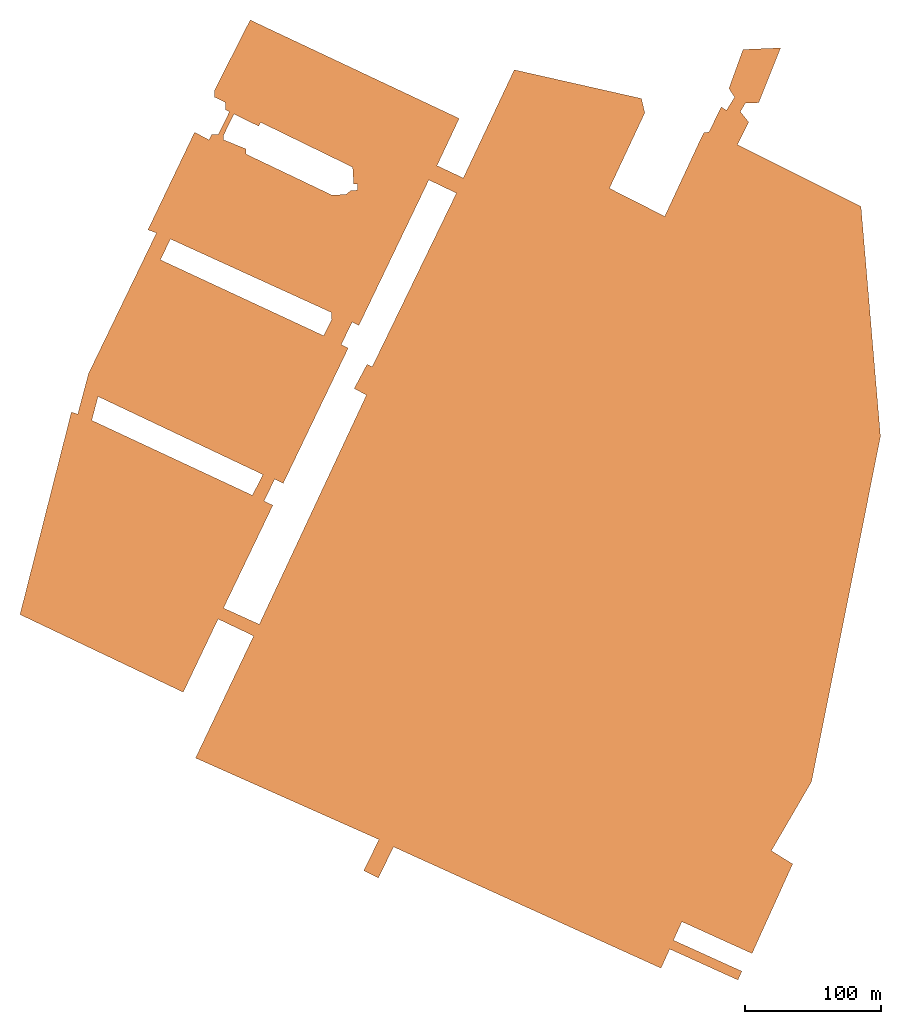
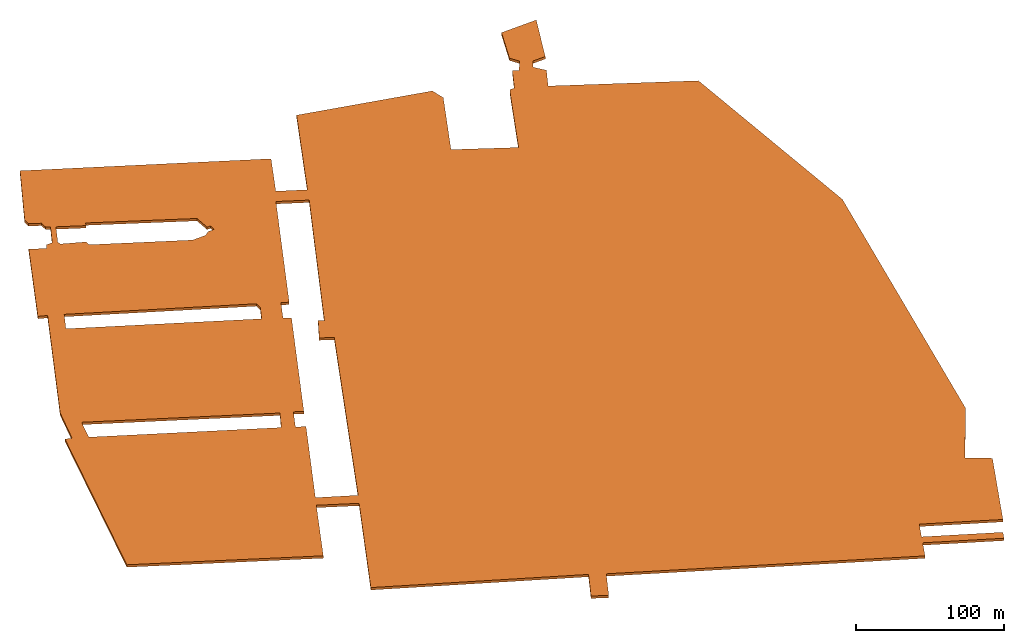
# One storey: 1 proxy.
"""IFC2X3 building model written with IfcOpenShell, lengths in millimetres."""

from ifc_helpers import new_model, entity, si_unit, converted_unit, direction, frame, origin, place, context, subcontext, project, spatial, polyline, outline, extrude, source, transform, mapped, material, element, save


model = new_model("IFC2X3")

# Units and contexts
model_context = context("Model", 3, precision=1e-06, world=origin(), true_north=direction((2.0, -0.438371146789077, 0.898794046299167)))
context_of_model = context(None, 3, precision=1e-06, world=origin(), true_north=direction((2.0, -0.438371146789077, 0.898794046299167)))
body_context = subcontext(model_context, "Body", "Model", "MODEL_VIEW")
ifc_project = project(units=[si_unit("LENGTHUNIT", "METRE", prefix="MILLI"), si_unit("AREAUNIT", "SQUARE_METRE", prefix="MILLI"), si_unit("VOLUMEUNIT", "CUBIC_METRE", prefix="MILLI"), converted_unit("PLANEANGLEUNIT", "DEGREE", entity("IfcRatioMeasure", 0.0174532925199433), si_unit("PLANEANGLEUNIT", "RADIAN"), dimensions=[0, 0, 0, 0, 0, 0, 0]), si_unit("TIMEUNIT", "SECOND")], contexts=[model_context, context_of_model])

# Site, building, storey
site_placement = place(None, frame((0.0, 0.0, 0.0), z_axis=(0.0, 0.0, 1.0), x_axis=(0.898794046299167, -0.438371146789077, 0.0)))
site = spatial("IfcSite", under=ifc_project, at=site_placement, CompositionType="ELEMENT")
building_placement = place(site_placement, origin())
building = spatial("IfcBuilding", under=site, at=building_placement, CompositionType="ELEMENT")
storey_placement = place(building_placement, origin())
storey = spatial("IfcBuildingStorey", under=building, at=storey_placement, Name="Level 1", CompositionType="ELEMENT", Elevation=0.0)

# Proxy
ifc_material = material(Name="Site - Hardcore")
shared_shape = source(origin(), body_context, "Body", "SweptSolid", [
    extrude(outline(polyline([(-68289.0261136773, -281372.315557075), (101742.240886323, -281372.315557075), (154613.315647112, -194518.60623515), (170531.291623267, -204208.468699819), (178660.623901406, -198784.962177654), (184600.757251726, -202898.681626879), (184180.103188965, -212782.214426559), (222977.182983261, -232302.144662709), (224156.972808639, -204582.237812576), (196420.103106178, -191838.758559945), (189703.293206404, -195462.859786934), (180587.565476673, -188689.298708977), (183289.636456157, -185052.903750417), (165634.882127878, -174380.951655873), (165788.850620511, -170763.364707875), (159708.355828297, -167150.186945574), (106636.851537343, -136814.6232652), (130657.392112296, -97969.779053489), (183783.178764957, -128606.116661553), (194491.149207645, -127057.832419954), (223443.349370865, -35546.5064534661), (147248.225374194, 8560.7309413074), (157981.098449312, 27101.7378848996), (191184.373744228, 7881.28559216693), (276388.507637952, 155071.17846518), (226889.332355256, 185711.279241667), (221969.71665208, 185920.663514953), (217483.991918389, 178489.463109385), (212091.107671838, 178718.990214145), (210304.816499651, 175976.874431154), (194481.528359476, 185595.567049761), (194682.910686013, 190327.171961732), (190995.94481385, 192721.68952609), (197529.767402745, 202782.163192516), (128822.003728601, 243080.206246699), (125995.439705228, 237029.609099254), (111148.280058021, 245817.880158233), (27077.9719497347, 295580.439006079), (-1982.78020482878, 305984.766080926), (-142.045793632339, 310542.08200674), (-145399.004149904, 360794.376373224), (-212503.197987397, 245882.968860104), (-160975.085650725, 215792.375479065), (-175602.624075941, 190743.702173125), (-261539.157821611, 240927.59551316), (-332739.058210901, 111442.505181481), (-354554.501088187, 124600.841406572), (-360754.756949129, 114321.325421792), (-339003.856774846, 101201.919169004), (-444594.095620093, -87426.639254179), (-431084.024916093, -94989.2883269198), (-458006.020214648, -143083.29037274), (-451839.856343459, -146534.977229494), (-424831.753766415, -98287.1513833974), (-411752.012221469, -105608.911382573), (-439454.783947064, -155097.708378136), (-376318.13542026, -190440.255941253), (-365286.928846469, -175645.357355356), (-317229.406995717, -209332.678951613), (-68289.0261136773, -281372.315557075)]), holes=[polyline([(208401.361809186, 172846.228789629), (197980.516576175, 155390.807748516), (200687.349265616, 153774.83501077), (162055.676614531, 89064.91018519), (149747.292329217, 89294.145371408), (149636.276815114, 86685.7657738974), (144894.947207046, 86887.5619942315), (145100.008589559, 91705.6086492848), (142455.347184059, 95722.6209450821), (142892.143104918, 105985.416892537), (178287.718199016, 166454.892180527), (182172.915687131, 166289.533887988), (190201.188545535, 182083.318635499), (193151.963625812, 181950.083574409), (208401.361809186, 172846.228789629)]), polyline([(56805.5141058907, 113592.928623963), (51657.9083053353, 113812.016407388), (40243.7361288054, 120769.203497019), (106078.916254454, 235826.832318125), (120662.677026295, 227120.361499651), (56805.5141058907, 113592.928623963)]), polyline([(48487.0923816568, 99073.757507861), (45654.0950147839, 94267.0452143577), (148005.66810612, 33942.7072141493), (136571.539171632, 14542.559244519), (14359.2510035068, 87148.5027180668), (16634.189891978, 90670.6748599874), (-359.813741441145, 101646.946938333), (-5910.14826453906, 93053.6463733529), (-167449.712632132, 185869.459528114), (-153270.804171236, 211162.377582565), (-80959.5524148727, 168543.312135702), (-77318.7732398086, 174720.57803201), (-61886.7950042409, 165625.223236989), (-65460.5780753029, 159561.62881828), (29648.7824443334, 103505.732092098), (32566.8960337036, 108456.860048616), (48487.0923816568, 99073.757507861)]), polyline([(-72370.3366708779, 182956.433505697), (-7440.6859589806, 296096.323698103), (9689.04923056504, 290038.93143938), (-57853.4225705501, 173892.111226867), (-72370.3366708779, 182956.433505697)])]), frame((-92565.8518675549, 33975.6624659825, -2000.0), z_axis=(0.0, 0.0, 1.0), x_axis=(-0.512598978146693, 0.858628142796966, 0.0)), (0.0, 0.0, 1.0), 2000.0),
])
proxy_placement = place(storey_placement, origin())
element("IfcBuildingElementProxy", 1, at=proxy_placement, inside=storey, material=ifc_material, CompositionType="ELEMENT", context=body_context, shape_type="MappedRepresentation", body=[
    mapped(shared_shape, transform((0.0, 0.0, 0.0), scale=1.0)),
])

save(model, "model.ifc")
